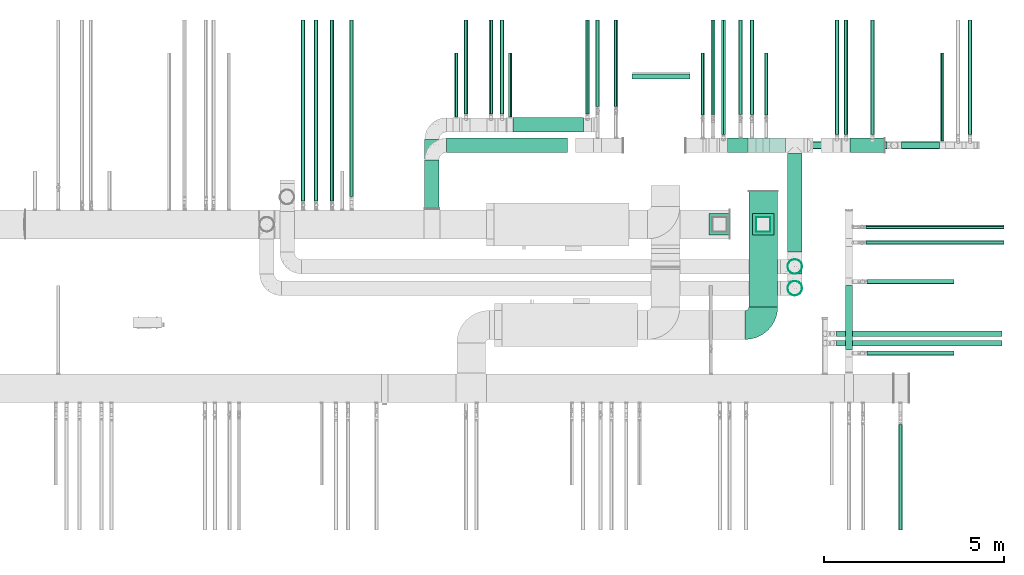
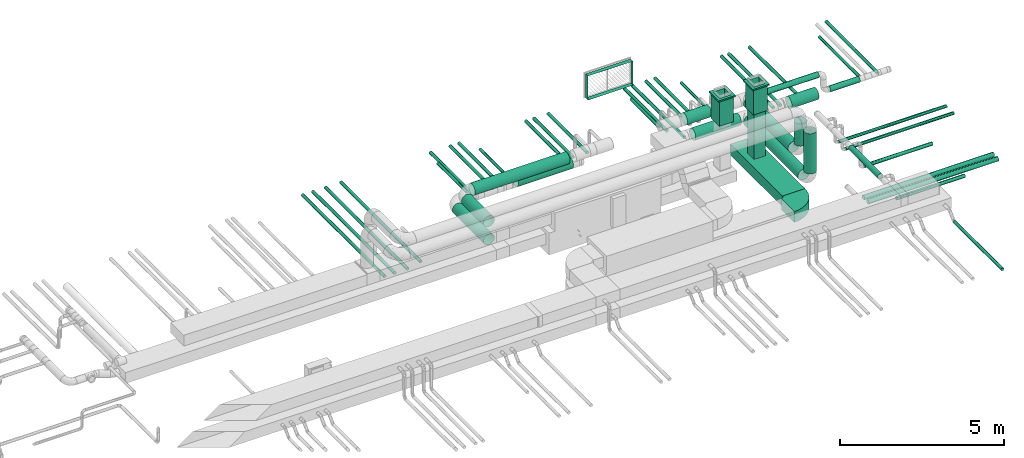
# One storey, part 4 of 91: 47 flow segments, 2 flow controllers, 1 flow fitting.
"""IFC2X3 building model written with IfcOpenShell, lengths in millimetres."""

from ifc_helpers import new_model, entity, si_unit, converted_unit, derived_unit, direction, frame, origin_with_axes, origin_2d_with_axis, place, context, subcontext, project, spatial, hollow_rectangle, hollow_circle, extrude, open_shell, surface_model, source, transform, mapped, material, layer, layer_set, layer_usage, type_object, element, save


model = new_model("IFC2X3")

# Units and contexts
model_context = context("Model", 3, precision=1e-05, world=origin_with_axes(), true_north=direction((0.0, 1.0)))
body_context = subcontext(model_context, "Body", "Model", "MODEL_VIEW")
ifc_project = project(units=[si_unit("AREAUNIT", "SQUARE_METRE"), si_unit("VOLUMEUNIT", "CUBIC_METRE", prefix="DECI"), si_unit("TIMEUNIT", "SECOND"), si_unit("THERMODYNAMICTEMPERATUREUNIT", "DEGREE_CELSIUS"), si_unit("PRESSUREUNIT", "PASCAL"), si_unit("MASSUNIT", "GRAM", prefix="KILO"), si_unit("LENGTHUNIT", "METRE", prefix="MILLI"), si_unit("POWERUNIT", "WATT"), si_unit("ELECTRICCURRENTUNIT", "AMPERE"), si_unit("ELECTRICVOLTAGEUNIT", "VOLT"), derived_unit("VOLUMETRICFLOWRATEUNIT", [(si_unit("VOLUMEUNIT", "CUBIC_METRE", prefix="DECI"), 1), (si_unit("TIMEUNIT", "SECOND"), -1)]), derived_unit("LINEARVELOCITYUNIT", [(si_unit("LENGTHUNIT", "METRE"), 1), (si_unit("TIMEUNIT", "SECOND"), -1)]), derived_unit("MASSDENSITYUNIT", [(si_unit("MASSUNIT", "GRAM", prefix="KILO"), 1), (si_unit("VOLUMEUNIT", "CUBIC_METRE"), -1)]), converted_unit("PLANEANGLEUNIT", "DEGREE", entity("IfcRatioMeasure", 0.01745), si_unit("PLANEANGLEUNIT", "RADIAN"), dimensions=[0, 0, 0, 0, 0, 0, 0])], contexts=[model_context])

# Site, building, storey
site_placement = place(None, origin_with_axes())
site = spatial("IfcSite", under=ifc_project, at=site_placement, CompositionType="ELEMENT")
building_placement = place(site_placement, origin_with_axes())
building = spatial("IfcBuilding", under=site, at=building_placement, Name="mc-building", CompositionType="ELEMENT")
storey_placement = place(building_placement, frame((0.0, 0.0, 8700.0), z_axis=(0.0, 0.0, 1.0), x_axis=(1.0, 0.0, 0.0)))
storey = spatial("IfcBuildingStorey", under=building, at=storey_placement, CompositionType="ELEMENT", Elevation=8700.0)

# Flow segments
ifc_material_1 = material(Name="1")
ifc_layer_1 = layer(ifc_material_1, 0.0)
ifc_layer_set_1 = layer_set([ifc_layer_1], Name="1")
ifc_layer_usage_1 = layer_usage(ifc_layer_set_1, "AXIS1", "POSITIVE", 0.0)
duct_segment_type_1 = type_object("IfcDuctSegmentType", PredefinedType="RIGIDSEGMENT")
shared_shape_1 = source(origin_with_axes(), body_context, "Body", "SweptSolid", [
    extrude(hollow_rectangle(XDim=1600.0, YDim=900.0, WallThickness=2.0, at=origin_2d_with_axis()), frame((0.0, 0.0, 0.0), z_axis=(1.0, 0.0, 0.0), x_axis=(0.0, 1.0, 0.0)), (0.0, 0.0, 1.0), 140.0),
])
flow_segment_1_placement = place(storey_placement, frame((28160.24579, 12052.74866, 2200.0), z_axis=(0.0, 0.0, 1.0), x_axis=(0.0, -1.0, 0.0)))
element("IfcFlowSegment", 1, at=flow_segment_1_placement, inside=storey, type_object=duct_segment_type_1, material=ifc_layer_usage_1, context=body_context, shape_type="MappedRepresentation", body=[
    mapped(shared_shape_1, transform((0.0, 0.0, 0.0), scale=1.0)),
])
ifc_material_2 = material(Name="FZ1")
ifc_layer_2 = layer(ifc_material_2, 0.0)
ifc_layer_set_2 = layer_set([ifc_layer_2], Name="FZ1")
ifc_layer_usage_2 = layer_usage(ifc_layer_set_2, "AXIS1", "POSITIVE", 0.0)
duct_segment_type_2 = type_object("IfcDuctSegmentType", PredefinedType="RIGIDSEGMENT")
shared_shape_2 = source(origin_with_axes(), body_context, "Body", "SweptSolid", [
    extrude(hollow_circle(Radius=55.0, WallThickness=2.0, at=origin_2d_with_axis()), frame((0.0, 0.0, 0.0), z_axis=(1.0, 0.0, 0.0), x_axis=(0.0, 1.0, 0.0)), (0.0, 0.0, 1.0), 4886.1),
])
flow_segment_2_placement = place(storey_placement, frame((19589.29598, 13553.57591, 415.0), z_axis=(0.0, 0.0, 1.0), x_axis=(0.0, -1.0, 0.0)))
element("IfcFlowSegment", 2, at=flow_segment_2_placement, inside=storey, type_object=duct_segment_type_2, material=ifc_layer_usage_2, context=body_context, shape_type="MappedRepresentation", body=[
    mapped(shared_shape_2, transform((0.0, 0.0, 0.0), scale=1.0)),
])
shared_shape_3 = source(origin_with_axes(), body_context, "Body", "SweptSolid", [
    extrude(hollow_circle(Radius=55.0, WallThickness=2.0, at=origin_2d_with_axis()), frame((0.0, 0.0, 0.0), z_axis=(1.0, 0.0, 0.0), x_axis=(0.0, 1.0, 0.0)), (0.0, 0.0, 1.0), 5017.0),
])
for number, where, z_axis, x_axis in (
    (3, (18242.77608, 13553.57591, 415.0), (0.0, 0.0, 1.0), (0.0, -1.0, 0.0)),
    (4, (19046.0369, 13553.57591, 415.0), (0.0, 0.0, 1.0), (0.0, -1.0, 0.0)),
    (5, (18604.54349, 13553.57591, 415.0), (0.0, 0.0, 1.0), (0.0, -1.0, 0.0)),
):
    element("IfcFlowSegment", number, at=place(storey_placement, frame(where, z_axis=z_axis, x_axis=x_axis)), inside=storey, type_object=duct_segment_type_2, material=ifc_layer_usage_2, context=body_context, shape_type="MappedRepresentation", body=[
        mapped(shared_shape_3, transform((0.0, 0.0, 0.0), scale=1.0)),
    ])
shared_shape_4 = source(origin_with_axes(), body_context, "Body", "SweptSolid", [
    extrude(hollow_circle(Radius=55.0, WallThickness=2.0, at=origin_2d_with_axis()), frame((0.0, 0.0, 0.0), z_axis=(1.0, 0.0, 0.0), x_axis=(0.0, 1.0, 0.0)), (0.0, 0.0, 1.0), 2403.1),
])
for number, where, z_axis, x_axis in (
    (6, (26403.5823, 13553.57591, 415.0), (0.0, 0.0, 1.0), (0.0, -1.0, 0.0)),
    (7, (26911.82755, 13553.57591, 415.0), (0.0, 0.0, 1.0), (0.0, -1.0, 0.0)),
):
    element("IfcFlowSegment", number, at=place(storey_placement, frame(where, z_axis=z_axis, x_axis=x_axis)), inside=storey, type_object=duct_segment_type_2, material=ifc_layer_usage_2, context=body_context, shape_type="MappedRepresentation", body=[
        mapped(shared_shape_4, transform((0.0, 0.0, 0.0), scale=1.0)),
    ])
shared_shape_5 = source(origin_with_axes(), body_context, "Body", "SweptSolid", [
    extrude(hollow_circle(Radius=55.0, WallThickness=2.0, at=origin_2d_with_axis()), frame((0.0, 0.0, 0.0), z_axis=(1.0, 0.0, 0.0), x_axis=(0.0, 1.0, 0.0)), (0.0, 0.0, 1.0), 2609.3),
])
for number, where, z_axis, x_axis in (
    (8, (23757.14677, 13553.57591, 415.0), (0.0, 0.0, 1.0), (0.0, -1.0, 0.0)),
    (9, (23447.14677, 13553.57591, 415.0), (0.0, 0.0, 1.0), (0.0, -1.0, 0.0)),
    (10, (26120.56538, 13553.57591, 415.0), (0.0, 0.0, 1.0), (0.0, -1.0, 0.0)),
    (11, (22757.14677, 13553.57591, 415.0), (0.0, 0.0, 1.0), (0.0, -1.0, 0.0)),
):
    element("IfcFlowSegment", number, at=place(storey_placement, frame(where, z_axis=z_axis, x_axis=x_axis)), inside=storey, type_object=duct_segment_type_2, material=ifc_layer_usage_2, context=body_context, shape_type="MappedRepresentation", body=[
        mapped(shared_shape_5, transform((0.0, 0.0, 0.0), scale=1.0)),
    ])
shared_shape_6 = source(origin_with_axes(), body_context, "Body", "SweptSolid", [
    extrude(hollow_circle(Radius=55.0, WallThickness=2.0, at=origin_2d_with_axis()), frame((0.0, 0.0, 0.0), z_axis=(1.0, 0.0, 0.0), x_axis=(0.0, 1.0, 0.0)), (0.0, 0.0, 1.0), 3175.0),
])
for number, where, z_axis, x_axis in (
    (12, (33284.80157, 13553.57591, 415.0), (0.0, 0.0, 1.0), (0.0, -1.0, 0.0)),
    (13, (34011.69824, 13553.57591, 415.0), (0.0, 0.0, 1.0), (0.0, -1.0, 0.0)),
    (14, (33028.54629, 13553.57591, 415.0), (0.0, 0.0, 1.0), (0.0, -1.0, 0.0)),
    (15, (29888.82784, 13553.57591, 415.0), (0.0, 0.0, 1.0), (0.0, -1.0, 0.0)),
):
    element("IfcFlowSegment", number, at=place(storey_placement, frame(where, z_axis=z_axis, x_axis=x_axis)), inside=storey, type_object=duct_segment_type_2, material=ifc_layer_usage_2, context=body_context, shape_type="MappedRepresentation", body=[
        mapped(shared_shape_6, transform((0.0, 0.0, 0.0), scale=1.0)),
    ])
shared_shape_7 = source(origin_with_axes(), body_context, "Body", "SweptSolid", [
    extrude(hollow_circle(Radius=55.0, WallThickness=2.0, at=origin_2d_with_axis()), frame((0.0, 0.0, 0.0), z_axis=(1.0, 0.0, 0.0), x_axis=(0.0, 1.0, 0.0)), (0.0, 0.0, 1.0), 2616.3),
])
for number, where, z_axis, x_axis in (
    (16, (30674.56773, 13553.57591, 415.0), (0.0, 0.0, 1.0), (0.0, -1.0, 0.0)),
    (17, (30364.56773, 13553.57591, 415.0), (0.0, 0.0, 1.0), (0.0, -1.0, 0.0)),
    (18, (29597.94843, 13553.57591, 415.0), (0.0, 0.0, 1.0), (0.0, -1.0, 0.0)),
):
    element("IfcFlowSegment", number, at=place(storey_placement, frame(where, z_axis=z_axis, x_axis=x_axis)), inside=storey, type_object=duct_segment_type_2, material=ifc_layer_usage_2, context=body_context, shape_type="MappedRepresentation", body=[
        mapped(shared_shape_7, transform((0.0, 0.0, 0.0), scale=1.0)),
    ])
shared_shape_8 = source(origin_with_axes(), body_context, "Body", "SweptSolid", [
    extrude(hollow_circle(Radius=55.0, WallThickness=2.0, at=origin_2d_with_axis()), frame((0.0, 0.0, 0.0), z_axis=(1.0, 0.0, 0.0), x_axis=(0.0, 1.0, 0.0)), (0.0, 0.0, 1.0), 3174.0),
])
flow_segment_3_placement = place(storey_placement, frame((36722.77222, 13553.57591, 415.0), z_axis=(0.0, 0.0, 1.0), x_axis=(0.0, -1.0, 0.0)))
element("IfcFlowSegment", 19, at=flow_segment_3_placement, inside=storey, type_object=duct_segment_type_2, material=ifc_layer_usage_2, context=body_context, shape_type="MappedRepresentation", body=[
    mapped(shared_shape_8, transform((0.0, 0.0, 0.0), scale=1.0)),
])
shared_shape_9 = source(origin_with_axes(), body_context, "Body", "SweptSolid", [
    extrude(hollow_circle(Radius=55.0, WallThickness=2.0, at=origin_2d_with_axis()), frame((0.0, 0.0, 0.0), z_axis=(1.0, 0.0, 0.0), x_axis=(0.0, 1.0, 0.0)), (0.0, 0.0, 1.0), 2931.7),
])
flow_segment_4_placement = place(storey_placement, frame((34787.74688, -577.64676, 415.0), z_axis=(0.0, 0.0, 1.0), x_axis=(0.0, 1.0, 0.0)))
element("IfcFlowSegment", 20, at=flow_segment_4_placement, inside=storey, type_object=duct_segment_type_2, material=ifc_layer_usage_2, context=body_context, shape_type="MappedRepresentation", body=[
    mapped(shared_shape_9, transform((0.0, 0.0, 0.0), scale=1.0)),
])
shared_shape_10 = source(origin_with_axes(), body_context, "Body", "SweptSolid", [
    extrude(hollow_circle(Radius=50.0, WallThickness=2.0, at=origin_2d_with_axis()), frame((0.0, 0.0, 0.0), z_axis=(1.0, 0.0, 0.0), x_axis=(0.0, 1.0, 0.0)), (0.0, 0.0, 1.0), 1772.7),
])
for number, where, z_axis, x_axis in (
    (21, (22488.52671, 12633.41275, 668.0), (0.0, 0.0, 1.0), (0.0, -1.0, 0.0)),
    (22, (23976.55606, 12633.41275, 668.0), (0.0, 0.0, 1.0), (0.0, -1.0, 0.0)),
):
    element("IfcFlowSegment", number, at=place(storey_placement, frame(where, z_axis=z_axis, x_axis=x_axis)), inside=storey, type_object=duct_segment_type_2, material=ifc_layer_usage_2, context=body_context, shape_type="MappedRepresentation", body=[
        mapped(shared_shape_10, transform((0.0, 0.0, 0.0), scale=1.0)),
    ])
shared_shape_11 = source(origin_with_axes(), body_context, "Body", "SweptSolid", [
    extrude(hollow_circle(Radius=50.0, WallThickness=2.0, at=origin_2d_with_axis()), frame((0.0, 0.0, 0.0), z_axis=(1.0, 0.0, 0.0), x_axis=(0.0, 1.0, 0.0)), (0.0, 0.0, 1.0), 1706.2),
])
for number, where, z_axis, x_axis in (
    (23, (29312.94843, 12633.41275, 668.0), (0.0, 0.0, 1.0), (0.0, -1.0, 0.0)),
    (24, (31073.17179, 12633.41275, 668.0), (0.0, 0.0, 1.0), (0.0, -1.0, 0.0)),
):
    element("IfcFlowSegment", number, at=place(storey_placement, frame(where, z_axis=z_axis, x_axis=x_axis)), inside=storey, type_object=duct_segment_type_2, material=ifc_layer_usage_2, context=body_context, shape_type="MappedRepresentation", body=[
        mapped(shared_shape_11, transform((0.0, 0.0, 0.0), scale=1.0)),
    ])
shared_shape_12 = source(origin_with_axes(), body_context, "Body", "SweptSolid", [
    extrude(hollow_circle(Radius=50.0, WallThickness=2.0, at=origin_2d_with_axis()), frame((0.0, 0.0, 0.0), z_axis=(1.0, 0.0, 0.0), x_axis=(0.0, 1.0, 0.0)), (0.0, 0.0, 1.0), 2437.4),
])
flow_segment_5_placement = place(storey_placement, frame((35954.21103, 12633.41275, 668.0), z_axis=(0.0, 0.0, 1.0), x_axis=(0.0, -1.0, 0.0)))
element("IfcFlowSegment", 25, at=flow_segment_5_placement, inside=storey, type_object=duct_segment_type_2, material=ifc_layer_usage_2, context=body_context, shape_type="MappedRepresentation", body=[
    mapped(shared_shape_12, transform((0.0, 0.0, 0.0), scale=1.0)),
])
shared_shape_13 = source(origin_with_axes(), body_context, "Body", "SweptSolid", [
    extrude(hollow_circle(Radius=80.0, WallThickness=2.0, at=origin_2d_with_axis()), frame((0.0, 0.0, 0.0), z_axis=(1.0, 0.0, 0.0), x_axis=(0.0, 1.0, 0.0)), (0.0, 0.0, 1.0), 4593.9),
])
for number, where, z_axis, x_axis in (
    (26, (37609.98441, 4601.38149, 415.0), (0.0, 0.0, 1.0), (-1.0, 0.0, 0.0)),
    (27, (37609.98441, 4863.15068, 415.0), (0.0, 0.0, 1.0), (-1.0, 0.0, 0.0)),
):
    element("IfcFlowSegment", number, at=place(storey_placement, frame(where, z_axis=z_axis, x_axis=x_axis)), inside=storey, type_object=duct_segment_type_2, material=ifc_layer_usage_2, context=body_context, shape_type="MappedRepresentation", body=[
        mapped(shared_shape_13, transform((0.0, 0.0, 0.0), scale=1.0)),
    ])
duct_segment_type_3 = type_object("IfcDuctSegmentType", Name="Safe", PredefinedType="RIGIDSEGMENT")
shared_shape_14 = source(origin_with_axes(), body_context, "Body", "SweptSolid", [
    extrude(hollow_circle(Radius=200.0, WallThickness=2.0, at=origin_2d_with_axis()), frame((0.0, 0.0, 0.0), z_axis=(1.0, 0.0, 0.0), x_axis=(0.0, 1.0, 0.0)), (0.0, 0.0, 1.0), 1905.4),
])
flow_segment_6_placement = place(storey_placement, frame((21810.56538, 10245.73579, 668.0), z_axis=(0.0, 0.0, 1.0), x_axis=(0.0, -1.0, 0.0)))
element("IfcFlowSegment", 28, at=flow_segment_6_placement, inside=storey, type_object=duct_segment_type_3, material=ifc_layer_usage_2, Name="Safe", context=body_context, shape_type="MappedRepresentation", body=[
    mapped(shared_shape_14, transform((0.0, 0.0, 0.0), scale=1.0)),
])
shared_shape_15 = source(origin_with_axes(), body_context, "Body", "SweptSolid", [
    extrude(hollow_circle(Radius=200.0, WallThickness=2.0, at=origin_2d_with_axis()), frame((0.0, 0.0, 0.0), z_axis=(1.0, 0.0, 0.0), x_axis=(0.0, 1.0, 0.0)), (0.0, 0.0, 1.0), 1946.5),
])
flow_segment_7_placement = place(storey_placement, frame((24064.05606, 10645.73579, 668.0), z_axis=(0.0, 0.0, 1.0), x_axis=(1.0, 0.0, 0.0)))
element("IfcFlowSegment", 29, at=flow_segment_7_placement, inside=storey, type_object=duct_segment_type_3, material=ifc_layer_usage_2, Name="Safe", context=body_context, shape_type="MappedRepresentation", body=[
    mapped(shared_shape_15, transform((0.0, 0.0, 0.0), scale=1.0)),
])

# Flow fitting
duct_fitting_type = type_object("IfcDuctFittingType", Name="R1", PredefinedType="BEND")
shared_shape_16 = source(origin_with_axes(), body_context, "Body", "SurfaceModel", [
    surface_model("IfcShellBasedSurfaceModel", [(-500.0, 400.0, 200.0), (-500.0, 400.0, -200.0), (-500.0, -400.0, -200.0), (-500.0, -400.0, 200.0), (400.0, 500.0, -200.0), (-400.0, 500.0, -200.0), (-400.0, 500.0, 200.0), (400.0, 500.0, 200.0), (-469.09829, 404.89436, 200.0), (-441.22147, 419.09829, -200.0), (-469.09829, 404.89436, -200.0), (-441.22147, 419.09829, 200.0), (-419.09829, 441.22147, -200.0), (-404.89436, 469.09829, -200.0), (-419.09829, 441.22147, 200.0), (-404.89436, 469.09829, 200.0), (310.87198, 109.50464, -200.0), (349.49498, 202.74885, -200.0), (-109.50464, -310.87198, -200.0), (136.3961, -136.3961, -200.0), (394.34097, 399.23195, -200.0), (377.43514, 299.73116, -200.0), (-399.23195, -394.34097, -200.0), (-202.74885, -349.49498, -200.0), (-299.73116, -377.43514, -200.0), (-21.17113, -262.05177, -200.0), (262.05177, 21.17113, -200.0), (203.64833, -61.14082, -200.0), (61.14082, -203.64833, -200.0), (-399.23195, -394.34097, 200.0), (-299.73116, -377.43514, 200.0), (-21.17113, -262.05177, 200.0), (-109.50464, -310.87198, 200.0), (61.14082, -203.64833, 200.0), (-202.74885, -349.49498, 200.0), (136.3961, -136.3961, 200.0), (203.64833, -61.14082, 200.0), (262.05177, 21.17113, 200.0), (377.43514, 299.73116, 200.0), (349.49498, 202.74885, 200.0), (310.87198, 109.50464, 200.0), (394.34097, 399.23195, 200.0)], [open_shell([[[0, 1, 2]], [[2, 3, 0]], [[4, 5, 6]], [[6, 7, 4]], [[8, 9, 10]], [[8, 10, 1]], [[1, 0, 8]], [[9, 8, 11]], [[11, 12, 9]], [[13, 12, 14]], [[5, 13, 15]], [[14, 15, 13]], [[6, 5, 15]], [[11, 14, 12]], [[16, 13, 17]], [[10, 9, 18]], [[9, 12, 19]], [[12, 13, 16]], [[20, 5, 4]], [[5, 20, 13]], [[20, 21, 13]], [[21, 17, 13]], [[22, 1, 10]], [[23, 10, 18]], [[10, 23, 24]], [[22, 10, 24]], [[25, 18, 9]], [[16, 26, 12]], [[12, 26, 27]], [[9, 19, 28]], [[27, 19, 12]], [[25, 9, 28]], [[22, 2, 1]], [[29, 2, 22]], [[30, 22, 24]], [[31, 25, 28]], [[32, 18, 25]], [[28, 19, 33]], [[23, 34, 30]], [[29, 22, 30]], [[2, 29, 3]], [[23, 32, 34]], [[23, 18, 32]], [[32, 25, 31]], [[28, 33, 31]], [[23, 30, 24]], [[19, 35, 33]], [[36, 27, 26]], [[16, 37, 26]], [[21, 20, 38]], [[39, 17, 21]], [[40, 16, 17]], [[41, 20, 4]], [[35, 27, 36]], [[36, 26, 37]], [[40, 37, 16]], [[17, 39, 40]], [[21, 38, 39]], [[41, 38, 20]], [[4, 7, 41]], [[27, 35, 19]], [[39, 15, 40]], [[32, 11, 8]], [[35, 14, 11]], [[40, 15, 14]], [[7, 6, 41]], [[15, 41, 6]], [[15, 38, 41]], [[15, 39, 38]], [[8, 0, 29]], [[32, 8, 34]], [[30, 34, 8]], [[30, 8, 29]], [[11, 32, 31]], [[14, 37, 40]], [[36, 37, 14]], [[33, 35, 11]], [[14, 35, 36]], [[33, 11, 31]], [[0, 3, 29]]])]),
])
flow_fitting_placement = place(storey_placement, frame((30990.3445, 5104.45799, 668.0), z_axis=(0.0, 0.0, 1.0), x_axis=(1.0, 0.0, 0.0)))
element("IfcFlowFitting", 30, at=flow_fitting_placement, inside=storey, type_object=duct_fitting_type, Name="R1", context=body_context, shape_type="MappedRepresentation", body=[
    mapped(shared_shape_16, transform((0.0, 0.0, 0.0), scale=1.0)),
])

# Flow segments
shared_shape_17 = source(origin_with_axes(), body_context, "Body", "SweptSolid", [
    extrude(hollow_rectangle(XDim=800.0, YDim=400.0, WallThickness=2.0, at=origin_2d_with_axis()), frame((0.0, 0.0, 0.0), z_axis=(1.0, 0.0, 0.0), x_axis=(0.0, 1.0, 0.0)), (0.0, 0.0, 1.0), 3200.0),
])
flow_segment_8_placement = place(storey_placement, frame((30990.3445, 5604.45799, 668.0), z_axis=(0.0, 0.0, 1.0), x_axis=(0.0, 1.0, 0.0)))
element("IfcFlowSegment", 31, at=flow_segment_8_placement, inside=storey, type_object=duct_segment_type_1, material=ifc_layer_usage_1, context=body_context, shape_type="MappedRepresentation", body=[
    mapped(shared_shape_17, transform((0.0, 0.0, 0.0), scale=1.0)),
])
shared_shape_18 = source(origin_with_axes(), body_context, "Body", "SweptSolid", [
    extrude(hollow_circle(Radius=55.0, WallThickness=2.0, at=origin_2d_with_axis()), frame((0.0, 0.0, 0.0), z_axis=(1.0, 0.0, 0.0), x_axis=(0.0, 1.0, 0.0)), (0.0, 0.0, 1.0), 3822.2),
])
for number, where, z_axis, x_axis in (
    (32, (37659.98441, 7819.73852, 415.0), (0.0, 0.0, 1.0), (-1.0, 0.0, 0.0)),
    (33, (37659.98441, 7384.97206, 415.0), (0.0, 0.0, 1.0), (-1.0, 0.0, 0.0)),
):
    element("IfcFlowSegment", number, at=place(storey_placement, frame(where, z_axis=z_axis, x_axis=x_axis)), inside=storey, type_object=duct_segment_type_2, material=ifc_layer_usage_2, context=body_context, shape_type="MappedRepresentation", body=[
        mapped(shared_shape_18, transform((0.0, 0.0, 0.0), scale=1.0)),
    ])
shared_shape_19 = source(origin_with_axes(), body_context, "Body", "SweptSolid", [
    extrude(hollow_circle(Radius=62.5, WallThickness=2.0, at=origin_2d_with_axis()), frame((0.0, 0.0, 0.0), z_axis=(1.0, 0.0, 0.0), x_axis=(0.0, 1.0, 0.0)), (0.0, 0.0, 1.0), 2412.2),
])
for number, where, z_axis, x_axis, name in (
    (34, (36279.9937, 6304.03427, 415.0), (0.0, 0.0, 1.0), (-1.0, 0.0, 0.0), "Safe"),
    (35, (36279.9937, 4322.30408, 415.0), (0.0, 0.0, 1.0), (-1.0, 0.0, 0.0), "Safe"),
):
    element("IfcFlowSegment", number, at=place(storey_placement, frame(where, z_axis=z_axis, x_axis=x_axis)), inside=storey, type_object=duct_segment_type_3, material=ifc_layer_usage_2, Name=name, context=body_context, shape_type="MappedRepresentation", body=[
        mapped(shared_shape_19, transform((0.0, 0.0, 0.0), scale=1.0)),
    ])
shared_shape_20 = source(origin_with_axes(), body_context, "Body", "SweptSolid", [
    extrude(hollow_circle(Radius=100.0, WallThickness=2.0, at=origin_2d_with_axis()), frame((0.0, 0.0, 0.0), z_axis=(1.0, 0.0, 0.0), x_axis=(0.0, 1.0, 0.0)), (0.0, 0.0, 1.0), 1766.7),
])
flow_segment_9_placement = place(storey_placement, frame((33364.76981, 4429.80408, 1344.0), z_axis=(0.0, 0.0, 1.0), x_axis=(0.0, 1.0, 0.0)))
element("IfcFlowSegment", 36, at=flow_segment_9_placement, inside=storey, type_object=duct_segment_type_3, material=ifc_layer_usage_2, Name="Safe", context=body_context, shape_type="MappedRepresentation", body=[
    mapped(shared_shape_20, transform((0.0, 0.0, 0.0), scale=1.0)),
])
shared_shape_21 = source(origin_with_axes(), body_context, "Body", "SweptSolid", [
    extrude(hollow_circle(Radius=200.0, WallThickness=2.0, at=origin_2d_with_axis()), frame((0.0, 0.0, 0.0), z_axis=(1.0, 0.0, 0.0), x_axis=(0.0, 1.0, 0.0)), (0.0, 0.0, 1.0), 3352.0),
])
flow_segment_10_placement = place(storey_placement, frame((22210.56538, 10080.05037, 1344.0), z_axis=(0.0, 0.0, 1.0), x_axis=(1.0, 0.0, 0.0)))
element("IfcFlowSegment", 37, at=flow_segment_10_placement, inside=storey, type_object=duct_segment_type_3, material=ifc_layer_usage_2, Name="Safe", context=body_context, shape_type="MappedRepresentation", body=[
    mapped(shared_shape_21, transform((0.0, 0.0, 0.0), scale=1.0)),
])
shared_shape_22 = source(origin_with_axes(), body_context, "Body", "SweptSolid", [
    extrude(hollow_circle(Radius=200.0, WallThickness=2.0, at=origin_2d_with_axis()), frame((0.0, 0.0, 0.0), z_axis=(1.0, 0.0, 0.0), x_axis=(0.0, 1.0, 0.0)), (0.0, 0.0, 1.0), 1339.7),
])
flow_segment_11_placement = place(storey_placement, frame((21810.56538, 9680.05037, 1344.0), z_axis=(0.0, 0.0, 1.0), x_axis=(0.0, -1.0, 0.0)))
element("IfcFlowSegment", 38, at=flow_segment_11_placement, inside=storey, type_object=duct_segment_type_3, material=ifc_layer_usage_2, Name="Safe", context=body_context, shape_type="MappedRepresentation", body=[
    mapped(shared_shape_22, transform((0.0, 0.0, 0.0), scale=1.0)),
])
shared_shape_23 = source(origin_with_axes(), body_context, "Body", "SweptSolid", [
    extrude(hollow_circle(Radius=200.0, WallThickness=2.0, at=origin_2d_with_axis()), frame((0.0, 0.0, 0.0), z_axis=(1.0, 0.0, 0.0), x_axis=(0.0, 1.0, 0.0)), (0.0, 0.0, 1.0), 1503.1),
])
flow_segment_12_placement = place(storey_placement, frame((31866.56389, 6120.95522, 2571.08071), z_axis=(-1.0, 0.0, 0.0), x_axis=(0.0, 0.0, -1.0)))
element("IfcFlowSegment", 39, at=flow_segment_12_placement, inside=storey, type_object=duct_segment_type_3, material=ifc_layer_usage_2, Name="Safe", context=body_context, shape_type="MappedRepresentation", body=[
    mapped(shared_shape_23, transform((0.0, 0.0, 0.0), scale=1.0)),
])
shared_shape_24 = source(origin_with_axes(), body_context, "Body", "SweptSolid", [
    extrude(hollow_circle(Radius=200.0, WallThickness=2.0, at=origin_2d_with_axis()), frame((0.0, 0.0, 0.0), z_axis=(1.0, 0.0, 0.0), x_axis=(0.0, 1.0, 0.0)), (0.0, 0.0, 1.0), 827.1),
])
flow_segment_13_placement = place(storey_placement, frame((31866.56389, 6720.97227, 1744.0), z_axis=(1.0, 0.0, 0.0), x_axis=(0.0, 0.0, 1.0)))
element("IfcFlowSegment", 40, at=flow_segment_13_placement, inside=storey, type_object=duct_segment_type_3, material=ifc_layer_usage_2, Name="Safe", context=body_context, shape_type="MappedRepresentation", body=[
    mapped(shared_shape_24, transform((0.0, 0.0, 0.0), scale=1.0)),
])
shared_shape_25 = source(origin_with_axes(), body_context, "Body", "SweptSolid", [
    extrude(hollow_circle(Radius=200.0, WallThickness=2.0, at=origin_2d_with_axis()), frame((0.0, 0.0, 0.0), z_axis=(1.0, 0.0, 0.0), x_axis=(0.0, 1.0, 0.0)), (0.0, 0.0, 1.0), 3334.1),
])
flow_segment_14_placement = place(storey_placement, frame((31866.56389, 6520.95522, 668.0), z_axis=(0.0, 0.0, 1.0), x_axis=(0.0, 1.0, 0.0)))
element("IfcFlowSegment", 41, at=flow_segment_14_placement, inside=storey, type_object=duct_segment_type_3, material=ifc_layer_usage_2, Name="Safe", context=body_context, shape_type="MappedRepresentation", body=[
    mapped(shared_shape_25, transform((0.0, 0.0, 0.0), scale=1.0)),
])
shared_shape_26 = source(origin_with_axes(), body_context, "Body", "SweptSolid", [
    extrude(hollow_circle(Radius=200.0, WallThickness=2.0, at=origin_2d_with_axis()), frame((0.0, 0.0, 0.0), z_axis=(1.0, 0.0, 0.0), x_axis=(0.0, 1.0, 0.0)), (0.0, 0.0, 1.0), 1612.7),
])
flow_segment_15_placement = place(storey_placement, frame((31611.56389, 10080.05037, 668.0), z_axis=(0.0, 0.0, 1.0), x_axis=(-1.0, 0.0, 0.0)))
element("IfcFlowSegment", 42, at=flow_segment_15_placement, inside=storey, type_object=duct_segment_type_3, material=ifc_layer_usage_2, Name="Safe", context=body_context, shape_type="MappedRepresentation", body=[
    mapped(shared_shape_26, transform((0.0, 0.0, 0.0), scale=1.0)),
])
shared_shape_27 = source(origin_with_axes(), body_context, "Body", "SweptSolid", [
    extrude(hollow_circle(Radius=200.0, WallThickness=2.0, at=origin_2d_with_axis()), frame((0.0, 0.0, 0.0), z_axis=(1.0, 0.0, 0.0), x_axis=(0.0, 1.0, 0.0)), (0.0, 0.0, 1.0), 2735.0),
])
flow_segment_16_placement = place(storey_placement, frame((31866.56389, 7120.97227, 1344.0), z_axis=(0.0, 0.0, 1.0), x_axis=(0.0, 1.0, 0.0)))
element("IfcFlowSegment", 43, at=flow_segment_16_placement, inside=storey, type_object=duct_segment_type_3, material=ifc_layer_usage_2, Name="Safe", context=body_context, shape_type="MappedRepresentation", body=[
    mapped(shared_shape_27, transform((0.0, 0.0, 0.0), scale=1.0)),
])
shared_shape_28 = source(origin_with_axes(), body_context, "Body", "SweptSolid", [
    extrude(hollow_circle(Radius=200.0, WallThickness=2.0, at=origin_2d_with_axis()), frame((0.0, 0.0, 0.0), z_axis=(1.0, 0.0, 0.0), x_axis=(0.0, 1.0, 0.0)), (0.0, 0.0, 1.0), 856.6),
])
flow_segment_17_placement = place(storey_placement, frame((30564.56773, 10080.96985, 1344.0), z_axis=(0.0, 0.0, 1.0), x_axis=(-1.0, 0.0, 0.0)))
element("IfcFlowSegment", 44, at=flow_segment_17_placement, inside=storey, type_object=duct_segment_type_3, material=ifc_layer_usage_2, Name="Safe", context=body_context, shape_type="MappedRepresentation", body=[
    mapped(shared_shape_28, transform((0.0, 0.0, 0.0), scale=1.0)),
])
shared_shape_29 = source(origin_with_axes(), body_context, "Body", "SweptSolid", [
    extrude(hollow_circle(Radius=200.0, WallThickness=2.0, at=origin_2d_with_axis()), frame((0.0, 0.0, 0.0), z_axis=(1.0, 0.0, 0.0), x_axis=(0.0, 1.0, 0.0)), (0.0, 0.0, 1.0), 955.2),
])
flow_segment_18_placement = place(storey_placement, frame((33394.80157, 10080.05037, 668.0), z_axis=(0.0, 0.0, 1.0), x_axis=(1.0, 0.0, 0.0)))
element("IfcFlowSegment", 45, at=flow_segment_18_placement, inside=storey, type_object=duct_segment_type_3, material=ifc_layer_usage_2, Name="Safe", context=body_context, shape_type="MappedRepresentation", body=[
    mapped(shared_shape_29, transform((0.0, 0.0, 0.0), scale=1.0)),
])
shared_shape_30 = source(origin_with_axes(), body_context, "Body", "SweptSolid", [
    extrude(hollow_circle(Radius=100.0, WallThickness=2.0, at=origin_2d_with_axis()), frame((0.0, 0.0, 0.0), z_axis=(1.0, 0.0, 0.0), x_axis=(0.0, 1.0, 0.0)), (0.0, 0.0, 1.0), 2104.0),
])
flow_segment_19_placement = place(storey_placement, frame((32317.56389, 10080.96985, 1344.0), z_axis=(0.0, 0.0, 1.0), x_axis=(1.0, 0.0, 0.0)))
element("IfcFlowSegment", 46, at=flow_segment_19_placement, inside=storey, type_object=duct_segment_type_3, material=ifc_layer_usage_2, Name="Safe", context=body_context, shape_type="MappedRepresentation", body=[
    mapped(shared_shape_30, transform((0.0, 0.0, 0.0), scale=1.0)),
])
shared_shape_31 = source(origin_with_axes(), body_context, "Body", "SweptSolid", [
    extrude(hollow_circle(Radius=100.0, WallThickness=2.0, at=origin_2d_with_axis()), frame((0.0, 0.0, 0.0), z_axis=(1.0, 0.0, 0.0), x_axis=(0.0, 1.0, 0.0)), (0.0, 0.0, 1.0), 1045.1),
])
flow_segment_20_placement = place(storey_placement, frame((34821.56389, 10080.96985, 668.0), z_axis=(0.0, 0.0, 1.0), x_axis=(1.0, 0.0, 0.0)))
element("IfcFlowSegment", 47, at=flow_segment_20_placement, inside=storey, type_object=duct_segment_type_3, material=ifc_layer_usage_2, Name="Safe", context=body_context, shape_type="MappedRepresentation", body=[
    mapped(shared_shape_31, transform((0.0, 0.0, 0.0), scale=1.0)),
])
shared_shape_32 = source(origin_with_axes(), body_context, "Body", "SweptSolid", [
    extrude(hollow_rectangle(XDim=400.0, YDim=400.0, WallThickness=2.0, at=origin_2d_with_axis()), frame((0.0, 0.0, 0.0), z_axis=(1.0, 0.0, 0.0), x_axis=(0.0, 1.0, 0.0)), (0.0, 0.0, 1.0), 1707.0),
])
flow_segment_21_placement = place(storey_placement, frame((30990.3445, 7890.34565, 893.0), z_axis=(0.0, -1.0, 0.0), x_axis=(0.0, 0.0, 1.0)))
element("IfcFlowSegment", 48, at=flow_segment_21_placement, inside=storey, type_object=duct_segment_type_1, material=ifc_layer_usage_1, context=body_context, shape_type="MappedRepresentation", body=[
    mapped(shared_shape_32, transform((0.0, 0.0, 0.0), scale=1.0)),
])

# Flow controllers
shared_shape_33 = source(origin_with_axes(), body_context, "Body", "SurfaceModel", [
    surface_model("IfcShellBasedSurfaceModel", [(450.0, -247.49999, -247.49999), (450.0, -200.0, -200.0), (450.0, -200.0, 200.0), (450.0, 200.0, -200.0), (450.0, -247.49999, 247.49999), (450.0, 200.0, 200.0), (450.0, 247.49999, -247.49999), (450.0, 247.49999, 247.49999), (-500.0, 247.49999, -247.49999), (-500.0, 200.0, -200.0), (-500.0, 200.0, 200.0), (-500.0, -200.0, -200.0), (-500.0, 247.49999, 247.49999), (-500.0, -200.0, 200.0), (-500.0, -247.49999, -247.49999), (-500.0, -247.49999, 247.49999), (450.0, 297.49999, -297.49999), (450.0, 297.49999, 297.49999), (450.0, -297.49999, -297.49999), (450.0, -297.49999, 297.49999), (500.0, -297.49999, -297.49999), (500.0, -200.0, -200.0), (500.0, -200.0, 200.0), (500.0, 200.0, -200.0), (500.0, -297.49999, 297.49999), (500.0, 200.0, 200.0), (500.0, 297.49999, -297.49999), (500.0, 297.49999, 297.49999)], [open_shell([[[0, 1, 2]], [[1, 0, 3]], [[4, 2, 5]], [[2, 4, 0]], [[3, 6, 5]], [[6, 3, 0]], [[5, 7, 4]], [[7, 5, 6]], [[8, 9, 10]], [[9, 8, 11]], [[12, 10, 13]], [[10, 12, 8]], [[11, 14, 13]], [[14, 11, 8]], [[13, 15, 12]], [[15, 13, 14]], [[6, 0, 14]], [[14, 8, 6]], [[7, 6, 8]], [[8, 12, 7]], [[4, 7, 12]], [[12, 15, 4]], [[0, 4, 15]], [[15, 14, 0]], [[2, 1, 11]], [[11, 13, 2]], [[5, 2, 13]], [[13, 10, 5]], [[3, 5, 10]], [[10, 9, 3]], [[1, 3, 9]], [[9, 11, 1]], [[16, 3, 5]], [[3, 16, 1]], [[17, 5, 2]], [[5, 17, 16]], [[1, 18, 2]], [[18, 1, 16]], [[2, 19, 17]], [[19, 2, 18]], [[20, 21, 22]], [[21, 20, 23]], [[24, 22, 25]], [[22, 24, 20]], [[23, 26, 25]], [[26, 23, 20]], [[25, 27, 24]], [[27, 25, 26]], [[26, 20, 18]], [[18, 16, 26]], [[27, 26, 16]], [[16, 17, 27]], [[24, 27, 17]], [[17, 19, 24]], [[20, 24, 19]], [[19, 18, 20]], [[22, 21, 1]], [[1, 2, 22]], [[25, 22, 2]], [[2, 5, 25]], [[23, 25, 5]], [[5, 3, 23]], [[21, 23, 3]], [[3, 1, 21]]])]),
])
for number, where, z_axis, x_axis, name in (
    (49, (29783.84753, 7890.34565, 3100.0), (-1.0, 0.0, 0.0), (0.0, 0.0, 1.0), "50-4-1000"),
    (50, (30990.3445, 7890.34565, 3100.0), (0.0, -1.0, 0.0), (0.0, 0.0, 1.0), "50-4-1000"),
):
    element("IfcFlowController", number, at=place(storey_placement, frame(where, z_axis=z_axis, x_axis=x_axis)), inside=storey, Name=name, context=body_context, shape_type="MappedRepresentation", body=[
        mapped(shared_shape_33, transform((0.0, 0.0, 0.0), scale=1.0)),
    ])

save(model, "model.ifc")
